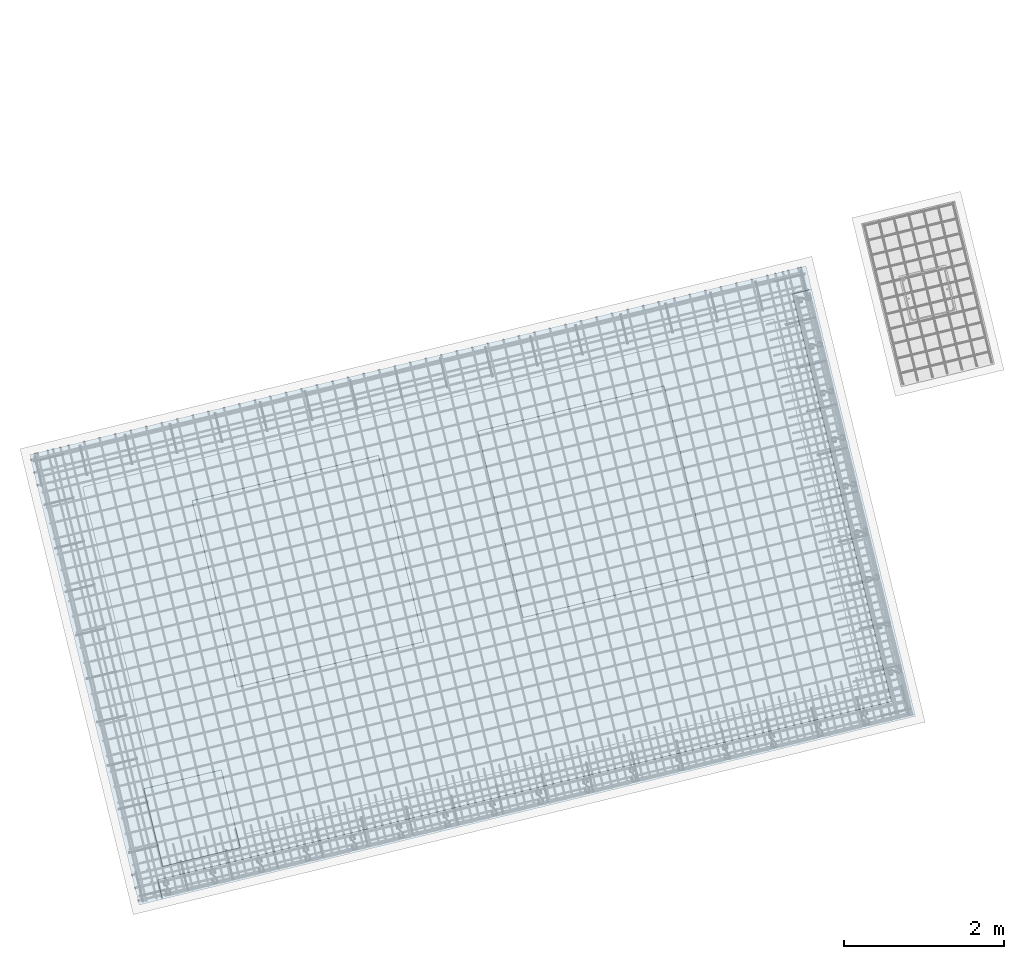
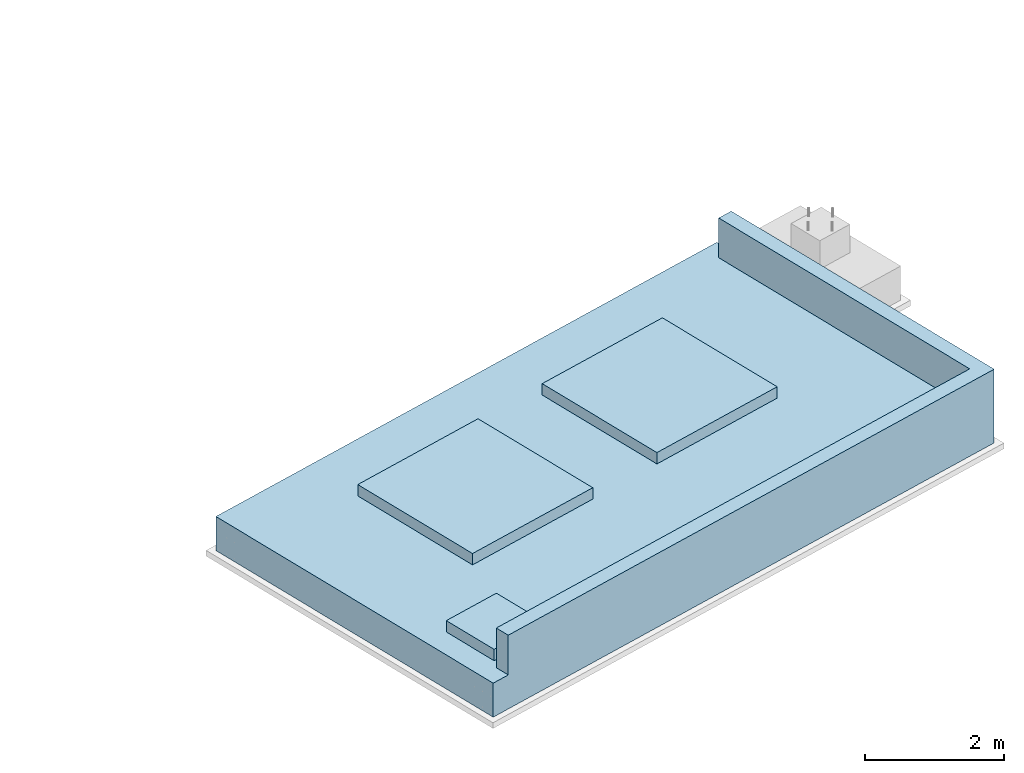
# One storey, part 25 of 25: 1 slab.
"""IFC2X3 building model written with IfcOpenShell, lengths in millimetres."""

from ifc_helpers import new_model, entity, si_unit, converted_unit, derived_unit, direction, frame, origin, place, context, subcontext, project, spatial, faceted_brep, type_object, element, save


model = new_model("IFC2X3")

# Units and contexts
model_context = context("Model", 3, precision=0.01, world=origin(), true_north=direction((6.12303176911189e-17, 1.0)))
body_context = subcontext(model_context, "Body", "Model", "MODEL_VIEW")
ifc_project = project(units=[si_unit("LENGTHUNIT", "METRE", prefix="MILLI"), si_unit("AREAUNIT", "SQUARE_METRE"), si_unit("VOLUMEUNIT", "CUBIC_METRE"), converted_unit("PLANEANGLEUNIT", "DEGREE", entity("IfcRatioMeasure", 0.0174532925199433), si_unit("PLANEANGLEUNIT", "RADIAN"), dimensions=[0, 0, 0, 0, 0, 0, 0]), si_unit("MASSUNIT", "GRAM", prefix="KILO"), derived_unit("MASSDENSITYUNIT", [(si_unit("MASSUNIT", "GRAM", prefix="KILO"), 1), (si_unit("LENGTHUNIT", "METRE"), -3)]), derived_unit("MOMENTOFINERTIAUNIT", [(si_unit("LENGTHUNIT", "METRE"), 4)]), si_unit("TIMEUNIT", "SECOND"), si_unit("FREQUENCYUNIT", "HERTZ"), si_unit("THERMODYNAMICTEMPERATUREUNIT", "DEGREE_CELSIUS"), derived_unit("THERMALTRANSMITTANCEUNIT", [(si_unit("MASSUNIT", "GRAM", prefix="KILO"), 1), (si_unit("THERMODYNAMICTEMPERATUREUNIT", "KELVIN"), -1), (si_unit("TIMEUNIT", "SECOND"), -3)]), derived_unit("VOLUMETRICFLOWRATEUNIT", [(si_unit("LENGTHUNIT", "METRE"), 3), (si_unit("TIMEUNIT", "SECOND"), -1)]), derived_unit("MASSFLOWRATEUNIT", [(si_unit("MASSUNIT", "GRAM", prefix="KILO"), 1), (si_unit("TIMEUNIT", "SECOND"), -1)]), derived_unit("ROTATIONALFREQUENCYUNIT", [(si_unit("TIMEUNIT", "SECOND"), -1)]), si_unit("ELECTRICCURRENTUNIT", "AMPERE"), si_unit("ELECTRICVOLTAGEUNIT", "VOLT"), si_unit("POWERUNIT", "WATT"), si_unit("FORCEUNIT", "NEWTON", prefix="KILO"), si_unit("ILLUMINANCEUNIT", "LUX"), si_unit("LUMINOUSFLUXUNIT", "LUMEN"), si_unit("LUMINOUSINTENSITYUNIT", "CANDELA"), derived_unit("USERDEFINED", [(si_unit("MASSUNIT", "GRAM", prefix="KILO"), -1), (si_unit("LENGTHUNIT", "METRE"), -2), (si_unit("TIMEUNIT", "SECOND"), 3), (si_unit("LUMINOUSFLUXUNIT", "LUMEN"), 1)]), derived_unit("LINEARVELOCITYUNIT", [(si_unit("LENGTHUNIT", "METRE"), 1), (si_unit("TIMEUNIT", "SECOND"), -1)]), si_unit("PRESSUREUNIT", "PASCAL"), derived_unit("USERDEFINED", [(si_unit("LENGTHUNIT", "METRE"), -2), (si_unit("MASSUNIT", "GRAM", prefix="KILO"), 1), (si_unit("TIMEUNIT", "SECOND"), -2)]), derived_unit("LINEARFORCEUNIT", [(si_unit("MASSUNIT", "GRAM", prefix="KILO"), 1), (si_unit("LENGTHUNIT", "METRE"), 1), (si_unit("TIMEUNIT", "SECOND"), -2), (si_unit("LENGTHUNIT", "METRE"), -1)]), derived_unit("PLANARFORCEUNIT", [(si_unit("MASSUNIT", "GRAM", prefix="KILO"), 1), (si_unit("LENGTHUNIT", "METRE"), 1), (si_unit("TIMEUNIT", "SECOND"), -2), (si_unit("LENGTHUNIT", "METRE"), -2)])], contexts=[model_context])

# Site, building, storey
site_placement = place(None, frame((19171.75, -72498.58, 0.0), z_axis=(0.0, 0.0, 1.0), x_axis=(0.971695960795463, 0.236234967296933, 0.0)))
site = spatial("IfcSite", under=ifc_project, at=site_placement, CompositionType="ELEMENT")
building_placement = place(site_placement, origin())
building = spatial("IfcBuilding", under=site, at=building_placement, CompositionType="ELEMENT")
storey_placement = place(building_placement, origin())
storey = spatial("IfcBuildingStorey", under=building, at=storey_placement, Name="01", CompositionType="ELEMENT", Elevation=0.0)

# Slab
slab_type = type_object("IfcSlabType", Name="Structural Foundations:Structural Foundations", PredefinedType="BASESLAB")
slab_placement = place(storey_placement, origin())
element("IfcSlab", 1, at=slab_placement, inside=storey, type_object=slab_type, Name="Structural Foundations:Structural Foundations", ObjectType="Structural Foundations:Structural Foundations", PredefinedType="BASESLAB", context=body_context, shape_type="Brep", body=[
    faceted_brep([(7920.0, 4760.0, 200.0), (5520.0, 4760.0, 200.0), (5520.0, 2360.0, 200.0), (7920.0, 2360.0, 200.0), (1840.0, 4760.0, 200.0), (4240.0, 4760.0, 200.0), (4240.0, 4760.0, 0.0), (1840.0, 4760.0, 0.0), (1840.0, 2360.0, 200.0), (1840.0, 2360.0, 0.0), (4240.0, 2360.0, 200.0), (4240.0, 2360.0, 0.0), (7920.0, 4760.0, 0.0), (5520.0, 4760.0, 0.0), (5520.0, 2360.0, 0.0), (7920.0, 2360.0, 0.0), (400.0, 1400.0, 0.0), (1400.0, 1400.0, 0.0), (1400.0, 400.0, 0.0), (400.0, 400.0, 0.0), (10000.0, 5800.0, 0.0), (0.0, 5800.0, 0.0), (0.0, 0.0, 0.0), (300.0, 0.0, 0.0), (300.0, 250.0, 0.0), (9750.0, 250.0, 0.0), (9750.0, 5500.0, 0.0), (10000.0, 5500.0, 0.0), (9550.0, 5350.0, -200.0), (9550.0, 450.0, -200.0), (1400.0, 450.0, -200.0), (1400.0, 1400.0, -200.0), (450.0, 1400.0, -200.0), (450.0, 5350.0, -200.0), (10000.0, 5800.0, -600.0), (0.0, 5800.0, -600.0), (0.0, 0.0, -600.0), (10000.0, 0.0, -600.0), (10000.0, 0.0, 700.0), (300.0, 0.0, 700.0), (10000.0, 5500.0, 700.0), (400.0, 1400.0, 200.0), (1400.0, 1400.0, 200.0), (400.0, 400.0, 200.0), (1400.0, 400.0, 200.0), (9550.0, 5350.0, -600.0), (450.0, 5350.0, -600.0), (450.0, 1400.0, -600.0), (1400.0, 1400.0, -600.0), (1400.0, 450.0, -600.0), (9550.0, 450.0, -600.0), (9750.0, 5500.0, 700.0), (9750.0, 250.0, 700.0), (300.0, 250.0, 700.0)], [[[0, 1, 2, 3]], [[4, 5, 6, 7]], [[8, 4, 7, 9]], [[10, 8, 9, 11]], [[5, 10, 11, 6]], [[1, 0, 12, 13]], [[2, 1, 13, 14]], [[3, 2, 14, 15]], [[0, 3, 15, 12]], [[7, 6, 11, 9], [13, 12, 15, 14], [16, 17, 18, 19], [20, 21, 22, 23, 24, 25, 26, 27]], [[28, 29, 30, 31, 32, 33]], [[21, 20, 34, 35]], [[22, 21, 35, 36]], [[36, 37, 38, 39, 23, 22]], [[38, 37, 34, 20, 27, 40]], [[41, 42, 17, 16]], [[43, 41, 16, 19]], [[44, 43, 19, 18]], [[42, 44, 18, 17]], [[34, 37, 36, 35], [45, 46, 47, 48, 49, 50]], [[45, 50, 29, 28]], [[50, 49, 30, 29]], [[49, 48, 31, 30]], [[48, 47, 32, 31]], [[47, 46, 33, 32]], [[46, 45, 28, 33]], [[39, 38, 40, 51, 52, 53]], [[51, 40, 27, 26]], [[52, 51, 26, 25]], [[53, 52, 25, 24]], [[39, 53, 24, 23]], [[5, 4, 8, 10]], [[42, 41, 43, 44]]], outer=[[True], [True], [True], [True], [True], [True], [True], [True], [True], [False, False, False, True], [True], [True], [True], [True], [True], [True], [True], [True], [True], [True, False], [True], [True], [True], [True], [True], [True], [True], [True], [True], [True], [True], [True], [True]]),
])

save(model, "model.ifc")
